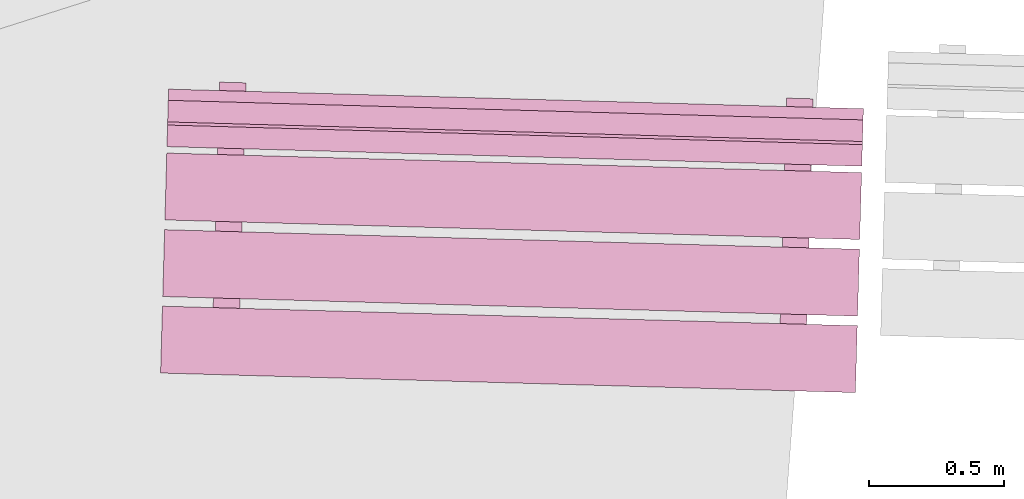
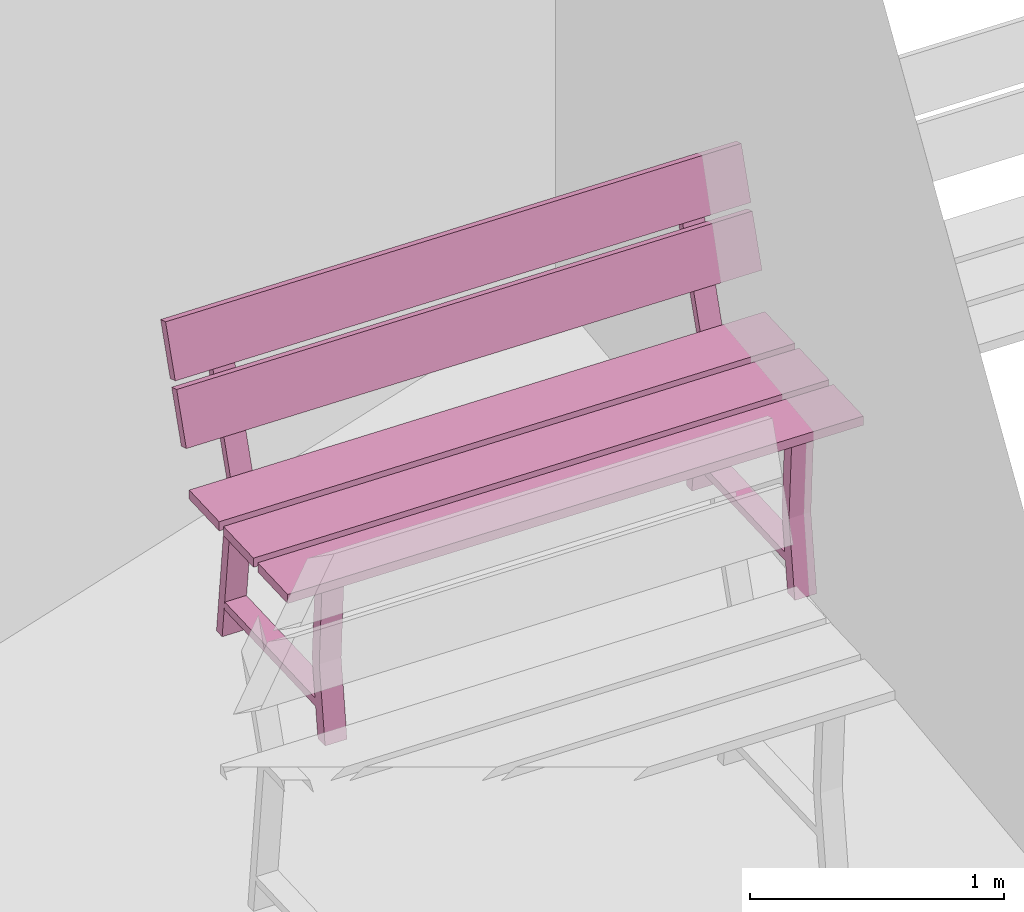
# One storey, part 20 of 200: 1 furnishing.
"""IFC4 building model written with IfcOpenShell, lengths in metres."""

from ifc_helpers import new_model, si_unit, origin_with_axes, place, context, subcontext, project, spatial, triangles, material, element, save


model = new_model("IFC4")

# Units and contexts
model_context = context("Model", 3, precision=1e-05, world=origin_with_axes())
body_context = subcontext(model_context, "Body", "Model", "MODEL_VIEW")
ifc_project = project(units=[si_unit("VOLUMEUNIT", "CUBIC_METRE"), si_unit("LENGTHUNIT", "METRE"), si_unit("AREAUNIT", "SQUARE_METRE")], contexts=[model_context])

# Site, building, storey
site_placement = place(None, origin_with_axes())
site = spatial("IfcSite", under=ifc_project, at=site_placement)
building_placement = place(site_placement, origin_with_axes())
building = spatial("IfcBuilding", under=site, at=building_placement, Name="Building")
storey_placement = place(building_placement, origin_with_axes())
storey = spatial("IfcBuildingStorey", under=building, at=storey_placement, Name="Ground")

# Furnishing
ifc_material = material(Name="bench")
furnishing_placement = place(storey_placement, origin_with_axes())
element("IfcFurnishingElement", 1, at=furnishing_placement, inside=storey, material=ifc_material, Name="cw_instances_bench_53", context=body_context, shape_type="Tessellation", body=[
    triangles([(239.1952935288997, -457.58333810020724, 0.8154595552323105), (239.20228697887356, -457.3351834237158, 0.8154595552323105), (236.6240483004857, -457.26252397005214, 0.8154595552323105), (236.61705485051186, -457.51067864654357, 0.8154595552323105), (236.80160765802376, -457.6526741380473, 0.3631407258093263), (236.8999057505293, -457.6554443570179, 0.3631407258093263), (236.89852969178983, -457.70427224777325, 1.4461350578594623e-07), (236.8002315992843, -457.7015020288026, 1.4461350578594623e-07), (236.89821736433422, -457.71535483490806, 0.3631407258093263), (236.79854773868846, -457.76125192091314, 1.606816730954958e-07), (236.896845831194, -457.76402213988376, 1.606816730954958e-07), (236.79991927182868, -457.71258461593743, 0.3631407258093263), (236.91968657765187, -456.9535440397656, 0.7741643170422662), (236.91968657765187, -456.9535440397656, 0.7741643170422662), (236.92221689007104, -456.8637587603763, 0.0), (236.82391879756548, -456.86098854140573, 0.0), (236.82391879756548, -456.86098854140573, 0.0), (236.82090664749856, -456.950760241734, 0.7741643170422662), (236.91848705349494, -456.9961078001729, 0.7346366254607741), (236.82259253082864, -456.90804961916416, 1.6068167309549576e-08), (236.9208906233342, -456.9108198381348, 1.6068167309549576e-08), (236.82018896098938, -456.9933375812023, 0.7352793682213234), (236.80092868370005, -457.6767667753405, 0.7352794646303272), (236.8992177231965, -457.67985823011753, 0.7346367218697779), (236.8975157583931, -457.74025052959365, 0.7741644616557719), (236.79873582823976, -457.73746673156205, 0.7741644616557719), (239.1872951958223, -457.86714991908343, 0.8154596516413144), (239.19428864534348, -457.6189952586538, 0.8154595552323105), (236.61604996695564, -457.5463358049901, 0.8154595552323105), (236.60905651743442, -457.79449046541976, 0.8154596516413144), (239.20330544239604, -457.2990443954979, 0.8154595552323105), (239.21029889191726, -457.05088973506827, 0.8154594588233067), (236.6320602135294, -456.97823028140465, 0.8154594588233067), (236.6250667640082, -457.2263849418343, 0.8154595552323105), (239.2109688150425, -457.02711826933427, 0.9999220838096051), (236.63498886423292, -456.8743104177313, 1.234838593466216), (236.63273013665463, -456.9544588156706, 0.9999220838096051), (239.21322754262076, -456.94696987139497, 1.234838593466216), (239.21355345140063, -456.9354053663034, 1.2690638219718915), (236.63757349968577, -456.78259754682404, 1.5039802352194984), (236.6353147730128, -456.86274591263975, 1.2690638219718915), (239.2158121780736, -456.8552570004877, 1.5039802352194984), (236.82787274605408, -456.71498213119224, 1.4583467364693816), (236.92617093493038, -456.71775235287873, 1.4583467364693816), (236.91968657765187, -456.9535440397656, 0.7741643170422662), (236.82090664749856, -456.950760241734, 0.7741643170422662), (236.8203066505602, -456.98916149965754, 0.7738429536960751), (236.91861832212675, -456.9914498809804, 0.7738429536960751), (236.92509815335333, -456.75581879593494, 1.4723259616878532), (236.82678638541606, -456.75353041189624, 1.4723259616878532), (236.63390250178432, -456.91285876268245, 0.9857820483726994), (236.6361567033107, -456.8328709665845, 1.2206986544383143), (239.21214118017215, -456.98551821634607, 0.9857820483726994), (239.21439538169855, -456.90553042024817, 1.2206986544383143), (236.6364871376898, -456.8211458757134, 1.2549238829439897), (236.63874586481543, -456.74099749383583, 1.4898404890096046), (239.21472581607765, -456.893805329377, 1.2549238829439897), (239.21698454320327, -456.8136569474995, 1.4898404890096046), (238.90522035217413, -457.7119577685188, 0.3631407258093263), (239.00351844467968, -457.7147279874894, 0.3631407258093263), (239.0021423859402, -457.76355587824474, 1.4461350578594623e-07), (238.90384429343467, -457.7607856592741, 1.4461350578594623e-07), (239.00183005848461, -457.77463846537955, 0.3631407258093263), (238.90216043283883, -457.82053555138464, 1.606816730954958e-07), (239.00045852534438, -457.82330577035526, 1.606816730954958e-07), (238.90353196597906, -457.7718682464089, 0.3631407258093263), (239.02329927180224, -457.01282767023713, 0.7741643170422662), (239.02329927180224, -457.01282767023713, 0.7741643170422662), (239.0258295842214, -456.9230423908478, 0.0), (238.92753149171585, -456.92027217187723, 0.0), (238.92753149171585, -456.92027217187723, 0.0), (238.92467989530496, -457.01004839689944, 0.7741643170422662), (239.0220997476453, -457.0553914306444, 0.7346366254607741), (238.92620522497901, -456.96733324963566, 1.6068167309549576e-08), (239.02450331748457, -456.9701034686063, 1.6068167309549576e-08), (238.92380165513978, -457.0526212116738, 0.7352793682213234), (238.90454137785042, -457.736050405812, 0.7352794646303272), (239.00283041734687, -457.73914186058903, 0.7346367218697779), (239.00112845254347, -457.79953416006515, 0.7741644616557719), (238.90250907604616, -457.7967548867275, 0.7741644616557719), (238.93164609023123, -456.77427028907357, 1.4583467364693816), (239.02978364514254, -456.77703598380293, 1.4583467364693816), (239.02329927180224, -457.01282767023713, 0.7741643170422662), (238.92467989530496, -457.01004839689944, 0.7741643170422662), (238.92391934471058, -457.0484451301291, 0.7738429536960751), (239.02223101627712, -457.0507335114519, 0.7738429536960751), (239.0287108635655, -456.8151024268591, 1.4723259616878532), (238.9305597295932, -456.81281856977756, 1.4723259616878532), (239.20228697887356, -457.3351834237158, 0.8154595552323105), (236.6240483004857, -457.26252397005214, 0.7715934584772401), (236.6240483004857, -457.26252397005214, 0.8154595552323105), (239.20228697887356, -457.3351834237158, 0.7715934584772401), (239.1952935288997, -457.58333810020724, 0.771593506681742), (236.61705485051186, -457.51067864654357, 0.8154595552323105), (236.61705485051186, -457.51067864654357, 0.771593506681742), (239.1952935288997, -457.58333810020724, 0.8154595552323105), (236.8002315992843, -457.7015020288026, 1.4461350578594623e-07), (236.79991927182868, -457.71258461593743, 0.3631407258093263), (236.80160765802376, -457.6526741380473, 0.3631407258093263), (236.79854773868846, -457.76125192091314, 1.606816730954958e-07), (236.82018896098938, -456.9933375812023, 0.7352793682213234), (236.82090664749856, -456.950760241734, 0.7741643170422662), (236.82391879756548, -456.86098854140573, 0.0), (236.82259253082864, -456.90804961916416, 1.6068167309549576e-08), (236.89821736433422, -457.71535483490806, 0.3631407258093263), (236.8999057505293, -457.6554443570179, 0.3631407258093263), (236.8992177231965, -457.67985823011753, 0.7346367218697779), (236.8975157583931, -457.74025052959365, 0.7741644616557719), (236.91968657765187, -456.9535440397656, 0.7741643170422662), (236.91848705349494, -456.9961078001729, 0.7346366254607741), (236.92221689007104, -456.8637587603763, 0.0), (236.9208906233342, -456.9108198381348, 1.6068167309549576e-08), (236.80092868370005, -457.6767667753405, 0.7352794646303272), (236.79873582823976, -457.73746673156205, 0.7741644616557719), (236.89852969178983, -457.70427224777325, 1.4461350578594623e-07), (236.896845831194, -457.76402213988376, 1.606816730954958e-07), (236.82787274605408, -456.71498213119224, 1.4583467364693816), (236.92509815335333, -456.75581879593494, 1.4723259616878532), (236.92617093493038, -456.71775235287873, 1.4583467364693816), (236.82678638541606, -456.75353041189624, 1.4723259616878532), (236.91944944359906, -456.92203137370274, 0.13995373726617685), (236.91944944359906, -456.92203137370274, 0.17948142884766885), (236.89764074515648, -457.69588841521374, 0.13995388187968263), (236.8976271651902, -457.6963702849851, 0.1794815734611746), (236.82307870168464, -456.9193154709761, 0.17948142884766885), (236.8233999856764, -456.9193245253431, 0.14059646395855885), (236.80160033979024, -457.6928603471095, 0.14059660857206463), (236.80125642327576, -457.6936543822584, 0.1794815734611746), (239.19428864534348, -457.6189952586538, 0.8154595552323105), (236.61604996695564, -457.5463358049901, 0.771593506681742), (236.61604996695564, -457.5463358049901, 0.8154595552323105), (239.19428864534348, -457.6189952586538, 0.771593506681742), (239.1872951958223, -457.86714991908343, 0.7715935548862439), (236.60905651743442, -457.79449046541976, 0.8154596516413144), (236.60905651743442, -457.79449046541976, 0.7715935548862439), (239.1872951958223, -457.86714991908343, 0.8154596516413144), (239.21029889191726, -457.05088973506827, 0.8154594588233067), (236.6320602135294, -456.97823028140465, 0.7715934102727381), (236.6320602135294, -456.97823028140465, 0.8154594588233067), (239.21029889191726, -457.05088973506827, 0.7715934102727381), (239.2033054419434, -457.2990444115597, 0.7715934584772401), (236.6250667640082, -457.2263849418343, 0.8154595552323105), (236.62506676355557, -457.2263849578961, 0.7715934584772401), (239.20330544239604, -457.2990443954979, 0.8154595552323105), (236.6361567033107, -456.8328709665845, 1.2206986544383143), (239.21322754262076, -456.94696987139497, 1.234838593466216), (239.21439538169855, -456.90553042024817, 1.2206986544383143), (236.63498886423292, -456.8743104177313, 1.234838593466216), (239.21214118017215, -456.98551821634607, 0.9857820483726994), (236.63273013665463, -456.9544588156706, 0.9999220838096051), (236.63390250178432, -456.91285876268245, 0.9857820483726994), (239.2109688150425, -457.02711826933427, 0.9999220838096051), (236.63874586481543, -456.74099749383583, 1.4898404890096046), (239.2158121780736, -456.8552570004877, 1.5039802352194984), (239.21698454320327, -456.8136569474995, 1.4898404890096046), (236.63757349968577, -456.78259754682404, 1.5039802352194984), (239.21472581607765, -456.893805329377, 1.2549238829439897), (236.6353147730128, -456.86274591263975, 1.2690638219718915), (236.6364871376898, -456.8211458757134, 1.2549238829439897), (239.21355345140063, -456.9354053663034, 1.2690638219718915), (238.90384429343467, -457.7607856592741, 1.4461350578594623e-07), (238.90353196597906, -457.7718682464089, 0.3631407258093263), (238.90522035217413, -457.7119577685188, 0.3631407258093263), (238.90216043283883, -457.82053555138464, 1.606816730954958e-07), (238.92380165513978, -457.0526212116738, 0.7352793682213234), (238.92467989530496, -457.01004839689944, 0.7741643170422662), (238.92753149171585, -456.92027217187723, 0.0), (238.92620522497901, -456.96733324963566, 1.6068167309549576e-08), (239.00183005848461, -457.77463846537955, 0.3631407258093263), (239.00351844467968, -457.7147279874894, 0.3631407258093263), (239.00283041734687, -457.73914186058903, 0.7346367218697779), (239.00112845254347, -457.79953416006515, 0.7741644616557719), (239.02329927180224, -457.01282767023713, 0.7741643170422662), (239.0220997476453, -457.0553914306444, 0.7346366254607741), (239.0258295842214, -456.9230423908478, 0.0), (239.02450331748457, -456.9701034686063, 1.6068167309549576e-08), (238.90454137785042, -457.736050405812, 0.7352794646303272), (238.90250907604616, -457.7967548867275, 0.7741644616557719), (239.0021423859402, -457.76355587824474, 1.4461350578594623e-07), (239.00045852534438, -457.82330577035526, 1.606816730954958e-07), (238.93164609023123, -456.77427028907357, 1.4583467364693816), (239.0287108635655, -456.8151024268591, 1.4723259616878532), (239.02978364514254, -456.77703598380293, 1.4583467364693816), (238.9305597295932, -456.81281856977756, 1.4723259616878532), (239.0232227877762, -456.98131953158406, 0.13995373726617685), (239.0232227877762, -456.98131953158406, 0.17948142884766885), (239.00141408933362, -457.75517657309507, 0.13995388187968263), (239.00140050936733, -457.75565844286643, 0.1794815734611746), (238.926691395835, -456.97859910144757, 0.17948142884766885), (238.9271732334828, -456.97861268050855, 0.14059646395855885), (238.90537358759664, -457.75214850227496, 0.14059660857206463), (238.90486911742613, -457.75293801272994, 0.1794815734611746), (239.1952935288997, -457.58333810020724, 0.8154595552323105), (239.20228697887356, -457.3351834237158, 0.7715934584772401), (239.20228697887356, -457.3351834237158, 0.8154595552323105), (239.1952935288997, -457.58333810020724, 0.771593506681742), (236.6240483004857, -457.26252397005214, 0.8154595552323105), (236.6240483004857, -457.26252397005214, 0.7715934584772401), (236.61705485051186, -457.51067864654357, 0.771593506681742), (236.61705485051186, -457.51067864654357, 0.8154595552323105), (239.1872951958223, -457.86714991908343, 0.8154596516413144), (239.19428864534348, -457.6189952586538, 0.771593506681742), (239.19428864534348, -457.6189952586538, 0.8154595552323105), (239.1872951958223, -457.86714991908343, 0.7715935548862439), (236.61604996695564, -457.5463358049901, 0.8154595552323105), (236.61604996695564, -457.5463358049901, 0.771593506681742), (236.60905651743442, -457.79449046541976, 0.7715935548862439), (236.60905651743442, -457.79449046541976, 0.8154596516413144), (239.20330544239604, -457.2990443954979, 0.8154595552323105), (239.21029889191726, -457.05088973506827, 0.7715934102727381), (239.21029889191726, -457.05088973506827, 0.8154594588233067), (239.2033054419434, -457.2990444115597, 0.7715934584772401), (236.6320602135294, -456.97823028140465, 0.8154594588233067), (236.6320602135294, -456.97823028140465, 0.7715934102727381), (236.62506676355557, -457.2263849578961, 0.7715934584772401), (236.6250667640082, -457.2263849418343, 0.8154595552323105), (239.21214118017215, -456.98551821634607, 0.9857820483726994), (239.21439538169855, -456.90553042024817, 1.2206986544383143), (239.21322754262076, -456.94696987139497, 1.234838593466216), (239.2109688150425, -457.02711826933427, 0.9999220838096051), (236.63498886423292, -456.8743104177313, 1.234838593466216), (236.63390250178432, -456.91285876268245, 0.9857820483726994), (236.63273013665463, -456.9544588156706, 0.9999220838096051), (236.6361567033107, -456.8328709665845, 1.2206986544383143), (239.21472581607765, -456.893805329377, 1.2549238829439897), (239.21698454320327, -456.8136569474995, 1.4898404890096046), (239.2158121780736, -456.8552570004877, 1.5039802352194984), (239.21355345140063, -456.9354053663034, 1.2690638219718915), (236.63757349968577, -456.78259754682404, 1.5039802352194984), (236.6364871376898, -456.8211458757134, 1.2549238829439897), (236.6353147730128, -456.86274591263975, 1.2690638219718915), (236.63874586481543, -456.74099749383583, 1.4898404890096046), (236.91861832212675, -456.9914498809804, 0.7738429536960751), (236.92509815335333, -456.75581879593494, 1.4723259616878532), (236.92617093493038, -456.71775235287873, 1.4583467364693816), (236.82090664749856, -456.950760241734, 0.7741643170422662), (236.8203066505602, -456.98916149965754, 0.7738429536960751), (236.82678638541606, -456.75353041189624, 1.4723259616878532), (236.82787274605408, -456.71498213119224, 1.4583467364693816), (239.02223101627712, -457.0507335114519, 0.7738429536960751), (239.0287108635655, -456.8151024268591, 1.4723259616878532), (239.02978364514254, -456.77703598380293, 1.4583467364693816), (238.92467989530496, -457.01004839689944, 0.7741643170422662), (238.92391934471058, -457.0484451301291, 0.7738429536960751), (238.9305597295932, -456.81281856977756, 1.4723259616878532), (238.93164609023123, -456.77427028907357, 1.4583467364693816), (236.91968657765187, -456.9535440397656, 0.7741643170422662), (236.82090664749856, -456.950760241734, 0.7741643170422662), (236.8975157583931, -457.74025052959365, 0.7741644616557719), (236.79873582823976, -457.73746673156205, 0.7741644616557719), (236.91944944359906, -456.92203137370274, 0.17948142884766885), (236.82307870168464, -456.9193154709761, 0.17948142884766885), (236.8976271651902, -457.6963702849851, 0.1794815734611746), (236.80125642327576, -457.6936543822584, 0.1794815734611746), (239.02329927180224, -457.01282767023713, 0.7741643170422662), (238.92467989530496, -457.01004839689944, 0.7741643170422662), (239.00112845254347, -457.79953416006515, 0.7741644616557719), (238.90250907604616, -457.7967548867275, 0.7741644616557719), (239.0232227877762, -456.98131953158406, 0.17948142884766885), (238.926691395835, -456.97859910144757, 0.17948142884766885), (239.00140050936733, -457.75565844286643, 0.1794815734611746), (238.90486911742613, -457.75293801272994, 0.1794815734611746)], [[1, 2, 3], [3, 4, 1], [5, 6, 7], [7, 8, 5], [9, 10, 11], [10, 9, 12], [14, 15, 16], [17, 18, 13], [19, 20, 21], [20, 19, 22], [23, 24, 5], [24, 6, 5], [12, 9, 25], [25, 26, 12], [27, 28, 29], [29, 30, 27], [31, 32, 33], [33, 34, 31], [35, 36, 37], [35, 38, 36], [39, 40, 41], [39, 42, 40], [43, 44, 45], [45, 46, 43], [47, 48, 49], [49, 50, 47], [51, 52, 53], [54, 53, 52], [55, 56, 57], [58, 57, 56], [59, 60, 61], [61, 62, 59], [63, 64, 65], [64, 63, 66], [68, 69, 71], [70, 72, 67], [73, 74, 75], [74, 73, 76], [77, 78, 59], [78, 60, 59], [66, 63, 79], [79, 80, 66], [81, 82, 83], [83, 84, 81], [85, 86, 87], [87, 88, 85], [89, 90, 91], [89, 92, 90], [93, 94, 95], [93, 96, 94], [97, 98, 99], [97, 100, 98], [101, 102, 103], [103, 104, 101], [105, 106, 107], [107, 108, 105], [109, 110, 111], [110, 112, 111], [108, 107, 109], [107, 110, 109], [113, 99, 98], [98, 114, 113], [115, 106, 105], [105, 116, 115], [117, 118, 119], [117, 120, 118], [102, 101, 113], [113, 114, 102], [121, 122, 123], [122, 124, 123], [125, 126, 127], [127, 128, 125], [129, 130, 131], [129, 132, 130], [133, 134, 135], [133, 136, 134], [137, 138, 139], [137, 140, 138], [141, 142, 143], [141, 144, 142], [145, 146, 147], [145, 148, 146], [149, 150, 151], [149, 152, 150], [153, 154, 155], [153, 156, 154], [157, 158, 159], [157, 160, 158], [161, 162, 163], [161, 164, 162], [165, 166, 167], [167, 168, 165], [169, 170, 171], [171, 172, 169], [173, 174, 175], [174, 176, 175], [172, 171, 173], [171, 174, 173], [177, 163, 162], [162, 178, 177], [179, 170, 169], [169, 180, 179], [181, 182, 183], [181, 184, 182], [166, 165, 177], [177, 178, 166], [185, 186, 187], [186, 188, 187], [189, 190, 191], [191, 192, 189], [193, 194, 195], [194, 193, 196], [197, 198, 199], [199, 200, 197], [201, 202, 203], [202, 201, 204], [205, 206, 207], [207, 208, 205], [209, 210, 211], [210, 209, 212], [213, 214, 215], [215, 216, 213], [217, 218, 219], [219, 220, 217], [221, 222, 223], [222, 221, 224], [225, 226, 227], [227, 228, 225], [229, 230, 231], [230, 229, 232], [233, 109, 234], [109, 235, 234], [236, 237, 238], [238, 239, 236], [240, 173, 241], [173, 242, 241], [243, 244, 245], [245, 246, 243], [247, 248, 249], [248, 250, 249], [251, 252, 253], [252, 254, 253], [255, 256, 257], [256, 258, 257], [259, 260, 261], [260, 262, 261]], closed=True),
])

save(model, "model.ifc")
